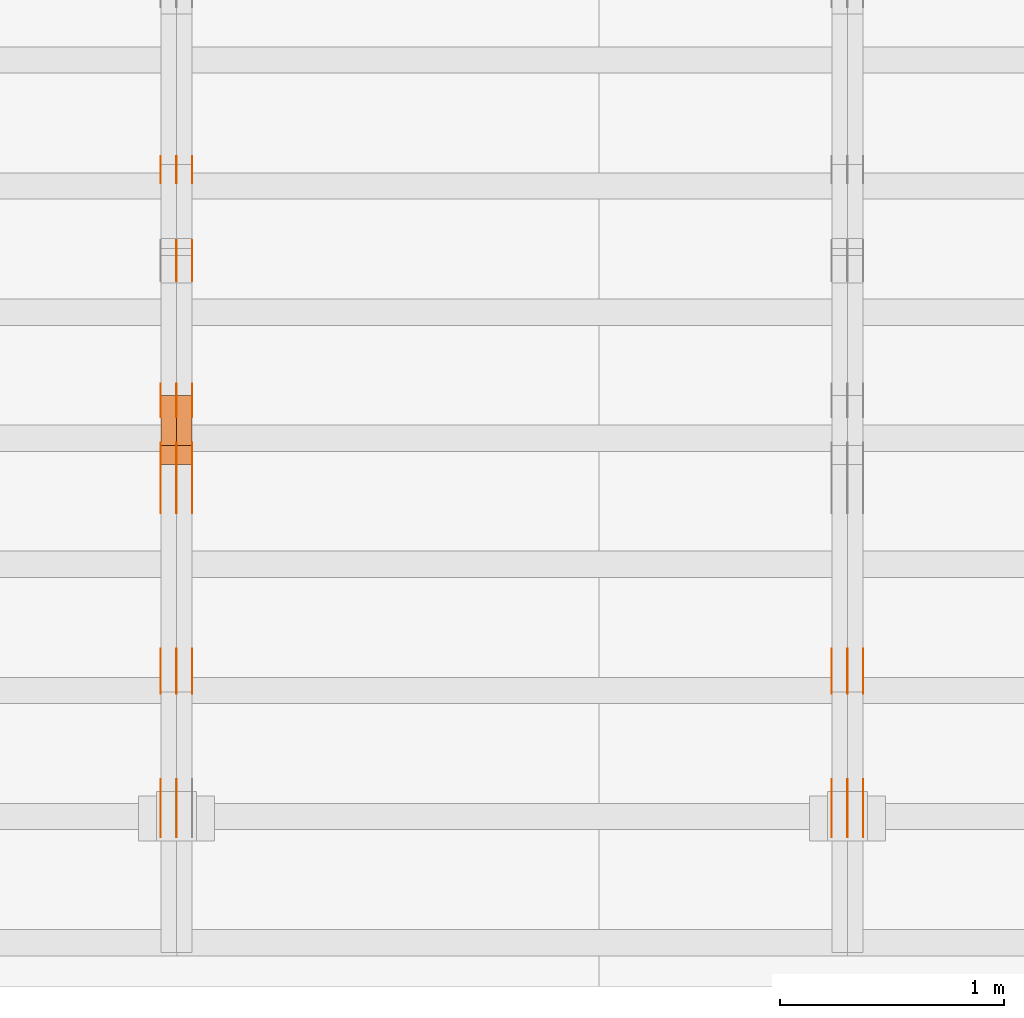
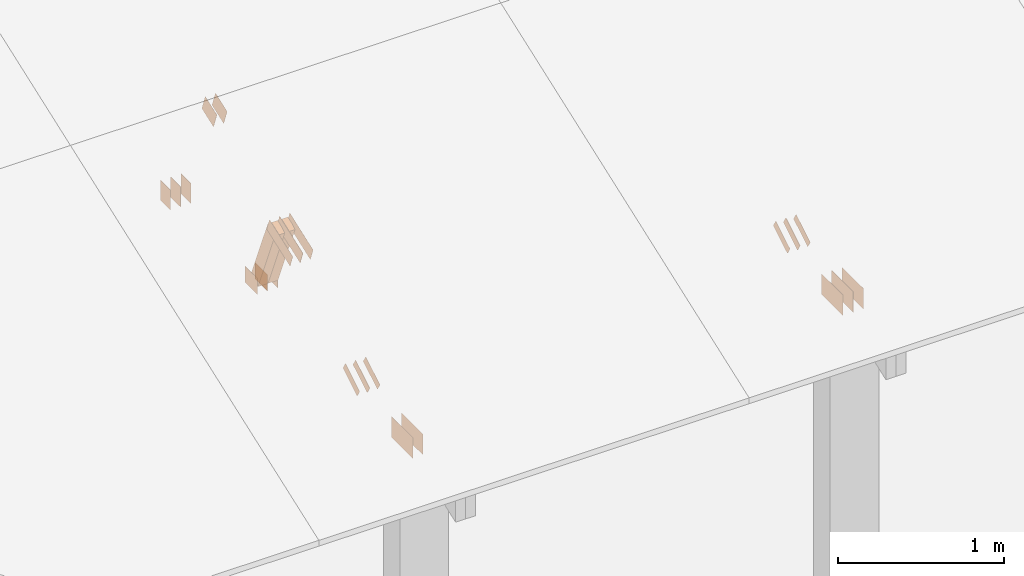
# One storey, part 68 of 189: 30 proxies.
"""IFC2X3 building model written with IfcOpenShell, lengths in millimetres."""

from ifc_helpers import new_model, entity, si_unit, converted_unit, derived_unit, direction, frame, frame_2d, origin, origin_2d_with_axis, place, context, subcontext, project, spatial, polyline, rectangle, outline, extrude, source, transform, mapped, material, type_object, type_shapes, element, save


model = new_model("IFC2X3")

# Units and contexts
model_context = context("Model", 3, precision=0.01, world=origin(), true_north=direction((6.12303176911189e-17, 1.0)))
body_context = subcontext(model_context, "Body", "Model", "MODEL_VIEW")
ifc_project = project(units=[si_unit("LENGTHUNIT", "METRE", prefix="MILLI"), si_unit("AREAUNIT", "SQUARE_METRE"), si_unit("VOLUMEUNIT", "CUBIC_METRE"), converted_unit("PLANEANGLEUNIT", "DEGREE", entity("IfcRatioMeasure", 0.0174532925199433), si_unit("PLANEANGLEUNIT", "RADIAN"), dimensions=[0, 0, 0, 0, 0, 0, 0]), si_unit("MASSUNIT", "GRAM", prefix="KILO"), derived_unit("MASSDENSITYUNIT", [(si_unit("MASSUNIT", "GRAM", prefix="KILO"), 1), (si_unit("LENGTHUNIT", "METRE"), -3)]), si_unit("TIMEUNIT", "SECOND"), si_unit("FREQUENCYUNIT", "HERTZ"), si_unit("THERMODYNAMICTEMPERATUREUNIT", "DEGREE_CELSIUS"), derived_unit("THERMALTRANSMITTANCEUNIT", [(si_unit("MASSUNIT", "GRAM", prefix="KILO"), 1), (si_unit("THERMODYNAMICTEMPERATUREUNIT", "KELVIN"), -1), (si_unit("TIMEUNIT", "SECOND"), -3)]), derived_unit("VOLUMETRICFLOWRATEUNIT", [(si_unit("LENGTHUNIT", "METRE"), 3), (si_unit("TIMEUNIT", "SECOND"), -1)]), si_unit("ELECTRICCURRENTUNIT", "AMPERE"), si_unit("ELECTRICVOLTAGEUNIT", "VOLT"), si_unit("POWERUNIT", "WATT"), si_unit("FORCEUNIT", "NEWTON"), si_unit("ILLUMINANCEUNIT", "LUX"), si_unit("LUMINOUSFLUXUNIT", "LUMEN"), si_unit("LUMINOUSINTENSITYUNIT", "CANDELA"), derived_unit("USERDEFINED", [(si_unit("MASSUNIT", "GRAM", prefix="KILO"), -1), (si_unit("LENGTHUNIT", "METRE"), -2), (si_unit("TIMEUNIT", "SECOND"), 3), (si_unit("LUMINOUSFLUXUNIT", "LUMEN"), 1)]), derived_unit("LINEARVELOCITYUNIT", [(si_unit("LENGTHUNIT", "METRE"), 1), (si_unit("TIMEUNIT", "SECOND"), -1)]), si_unit("PRESSUREUNIT", "PASCAL"), derived_unit("USERDEFINED", [(si_unit("LENGTHUNIT", "METRE"), -2), (si_unit("MASSUNIT", "GRAM", prefix="KILO"), 1), (si_unit("TIMEUNIT", "SECOND"), -2)])], contexts=[model_context])

# Site, building, storey
site_placement = place(None, origin())
site = spatial("IfcSite", under=ifc_project, at=site_placement, CompositionType="ELEMENT")
building_placement = place(site_placement, origin())
building = spatial("IfcBuilding", under=site, at=building_placement, CompositionType="ELEMENT")
storey_placement = place(building_placement, origin())
storey = spatial("IfcBuildingStorey", under=building, at=storey_placement, Name="Default", CompositionType="ELEMENT", Elevation=0.0)

# Proxies
ifc_material_1 = material(Name="IfcSurfaceStyle #40126")
building_element_proxy_type_1 = type_object("IfcBuildingElementProxyType", PredefinedType="NOTDEFINED", material=ifc_material_1)
shared_shape_1 = source(origin(), body_context, "Body", "SweptSolid", [
    extrude(outline(polyline([(-100.000388510424, -29.9995882393532), (100.000691805256, -29.9995882393532), (100.000392424258, 29.9995882393532), (-100.00069571909, 29.9995882393532), (-100.000388510424, -29.9995882393532)])), frame((100.000691805256, 30.0002299338894, 0.0), z_axis=(0.0, 0.0, 1.0), x_axis=(-1.0, 0.0, 0.0)), (0.0, 0.0, 1.0), 1.3),
])
type_shapes(building_element_proxy_type_1, [shared_shape_1])
proxy_1_placement = place(building_placement, frame((6336.3, 656.945055513712, 219.45219322107), z_axis=(-1.0, 0.0, 0.0), x_axis=(0.0, 0.858392121304013, 0.51299411895576)))
element("IfcBuildingElementProxy", 1, at=proxy_1_placement, inside=storey, type_object=building_element_proxy_type_1, material=ifc_material_1, context=body_context, shape_type="MappedRepresentation", body=[
    mapped(shared_shape_1, transform((0.0, 0.0, 0.0), scale=1.0)),
])
ifc_material_2 = material(Name="IfcSurfaceStyle #40069")
building_element_proxy_type_2 = type_object("IfcBuildingElementProxyType", PredefinedType="NOTDEFINED", material=ifc_material_2)
shared_shape_2 = source(origin(), body_context, "Body", "SweptSolid", [
    extrude(outline(polyline([(-100.000388510424, -29.9995882393532), (100.000691805256, -29.9995882393532), (100.000392424258, 29.9995882393532), (-100.00069571909, 29.9995882393532), (-100.000388510424, -29.9995882393532)])), frame((100.000691805256, 30.0002299338894, 0.0), z_axis=(0.0, 0.0, 1.0), x_axis=(-1.0, 0.0, 0.0)), (0.0, 0.0, 1.0), 1.29999999999998),
])
type_shapes(building_element_proxy_type_2, [shared_shape_2])
proxy_2_placement = place(building_placement, frame((6265.0, 656.945055513712, 219.45219322107), z_axis=(-1.0, 0.0, 0.0), x_axis=(0.0, 0.858392121304013, 0.51299411895576)))
element("IfcBuildingElementProxy", 2, at=proxy_2_placement, inside=storey, type_object=building_element_proxy_type_2, material=ifc_material_2, context=body_context, shape_type="MappedRepresentation", body=[
    mapped(shared_shape_2, transform((0.0, 0.0, 0.0), scale=1.0)),
])
ifc_material_3 = material(Name="IfcSurfaceStyle #40012")
building_element_proxy_type_3 = type_object("IfcBuildingElementProxyType", PredefinedType="NOTDEFINED", material=ifc_material_3)
shared_shape_3 = source(origin(), body_context, "Body", "SweptSolid", [
    extrude(outline(polyline([(-100.000388510424, -29.9995882393532), (100.000691805256, -29.9995882393532), (100.000392424258, 29.9995882393532), (-100.00069571909, 29.9995882393532), (-100.000388510424, -29.9995882393532)])), frame((100.000691805256, 30.0002299338894, 0.0), z_axis=(0.0, 0.0, 1.0), x_axis=(-1.0, 0.0, 0.0)), (0.0, 0.0, 1.0), 1.29999999999998),
])
type_shapes(building_element_proxy_type_3, [shared_shape_3])
proxy_3_placement = place(building_placement, frame((6266.3, 656.945055513712, 219.45219322107), z_axis=(-1.0, 0.0, 0.0), x_axis=(0.0, 0.858392121304013, 0.51299411895576)))
element("IfcBuildingElementProxy", 3, at=proxy_3_placement, inside=storey, type_object=building_element_proxy_type_3, material=ifc_material_3, context=body_context, shape_type="MappedRepresentation", body=[
    mapped(shared_shape_3, transform((0.0, 0.0, 0.0), scale=1.0)),
])
ifc_material_4 = material(Name="IfcSurfaceStyle #39955")
building_element_proxy_type_4 = type_object("IfcBuildingElementProxyType", PredefinedType="NOTDEFINED", material=ifc_material_4)
shared_shape_4 = source(origin(), body_context, "Body", "SweptSolid", [
    extrude(outline(polyline([(-100.000388510424, -29.9995882393532), (100.000691805256, -29.9995882393532), (100.000392424258, 29.9995882393532), (-100.00069571909, 29.9995882393532), (-100.000388510424, -29.9995882393532)])), frame((100.000691805256, 30.0002299338894, 0.0), z_axis=(0.0, 0.0, 1.0), x_axis=(-1.0, 0.0, 0.0)), (0.0, 0.0, 1.0), 1.29999999999999),
])
type_shapes(building_element_proxy_type_4, [shared_shape_4])
proxy_4_placement = place(building_placement, frame((6195.0, 656.945055513712, 219.45219322107), z_axis=(-1.0, 0.0, 0.0), x_axis=(0.0, 0.858392121304013, 0.51299411895576)))
element("IfcBuildingElementProxy", 4, at=proxy_4_placement, inside=storey, type_object=building_element_proxy_type_4, material=ifc_material_4, context=body_context, shape_type="MappedRepresentation", body=[
    mapped(shared_shape_4, transform((0.0, 0.0, 0.0), scale=1.0)),
])
ifc_material_5 = material(Name="IfcSurfaceStyle #38590")
building_element_proxy_type_5 = type_object("IfcBuildingElementProxyType", PredefinedType="NOTDEFINED", material=ifc_material_5)
shared_shape_5 = source(origin(), body_context, "Body", "SweptSolid", [
    extrude(rectangle(XDim=258.0, YDim=151.999992370605, at=origin_2d_with_axis()), frame((129.0, 76.0000049445079, 0.0), z_axis=(0.0, 0.0, 1.0), x_axis=(-1.0, 0.0, 0.0)), (0.0, 0.0, 1.0), 0.999999999999984),
])
type_shapes(building_element_proxy_type_5, [shared_shape_5])
proxy_5_placement = place(building_placement, frame((6336.0, 16.236328125, 268.138222870533), z_axis=(-1.0, 0.0, 0.0), x_axis=(0.0, 1.0, 0.0)))
element("IfcBuildingElementProxy", 5, at=proxy_5_placement, inside=storey, type_object=building_element_proxy_type_5, material=ifc_material_5, Name="GNT100S 152x258", context=body_context, shape_type="MappedRepresentation", body=[
    mapped(shared_shape_5, transform((0.0, 0.0, 0.0), scale=1.0)),
])
ifc_material_6 = material(Name="IfcSurfaceStyle #38533")
building_element_proxy_type_6 = type_object("IfcBuildingElementProxyType", PredefinedType="NOTDEFINED", material=ifc_material_6)
shared_shape_6 = source(origin(), body_context, "Body", "SweptSolid", [
    extrude(rectangle(XDim=258.0, YDim=151.999992370605, at=origin_2d_with_axis()), frame((129.0, 76.0000049445079, 0.0), z_axis=(0.0, 0.0, 1.0), x_axis=(-1.0, 0.0, 0.0)), (0.0, 0.0, 1.0), 0.999999999999984),
])
type_shapes(building_element_proxy_type_6, [shared_shape_6])
proxy_6_placement = place(building_placement, frame((6265.0, 16.236328125, 268.138222870533), z_axis=(-1.0, 0.0, 0.0), x_axis=(0.0, 1.0, 0.0)))
element("IfcBuildingElementProxy", 6, at=proxy_6_placement, inside=storey, type_object=building_element_proxy_type_6, material=ifc_material_6, Name="GNT100S 152x258", context=body_context, shape_type="MappedRepresentation", body=[
    mapped(shared_shape_6, transform((0.0, 0.0, 0.0), scale=1.0)),
])
ifc_material_7 = material(Name="IfcSurfaceStyle #38476")
building_element_proxy_type_7 = type_object("IfcBuildingElementProxyType", PredefinedType="NOTDEFINED", material=ifc_material_7)
shared_shape_7 = source(origin(), body_context, "Body", "SweptSolid", [
    extrude(rectangle(XDim=258.0, YDim=151.999992370605, at=origin_2d_with_axis()), frame((129.0, 76.0000049445079, 0.0), z_axis=(0.0, 0.0, 1.0), x_axis=(-1.0, 0.0, 0.0)), (0.0, 0.0, 1.0), 0.999999999999984),
])
type_shapes(building_element_proxy_type_7, [shared_shape_7])
proxy_7_placement = place(building_placement, frame((6266.0, 16.236328125, 268.138222870533), z_axis=(-1.0, 0.0, 0.0), x_axis=(0.0, 1.0, 0.0)))
element("IfcBuildingElementProxy", 7, at=proxy_7_placement, inside=storey, type_object=building_element_proxy_type_7, material=ifc_material_7, Name="GNT100S 152x258", context=body_context, shape_type="MappedRepresentation", body=[
    mapped(shared_shape_7, transform((0.0, 0.0, 0.0), scale=1.0)),
])
ifc_material_8 = material(Name="IfcSurfaceStyle #38419")
building_element_proxy_type_8 = type_object("IfcBuildingElementProxyType", PredefinedType="NOTDEFINED", material=ifc_material_8)
shared_shape_8 = source(origin(), body_context, "Body", "SweptSolid", [
    extrude(rectangle(XDim=258.0, YDim=151.999992370605, at=origin_2d_with_axis()), frame((129.0, 76.0000049445079, 0.0), z_axis=(0.0, 0.0, 1.0), x_axis=(-1.0, 0.0, 0.0)), (0.0, 0.0, 1.0), 0.999999999999984),
])
type_shapes(building_element_proxy_type_8, [shared_shape_8])
proxy_8_placement = place(building_placement, frame((6195.0, 16.236328125, 268.138222870533), z_axis=(-1.0, 0.0, 0.0), x_axis=(0.0, 1.0, 0.0)))
element("IfcBuildingElementProxy", 8, at=proxy_8_placement, inside=storey, type_object=building_element_proxy_type_8, material=ifc_material_8, Name="GNT100S 152x258", context=body_context, shape_type="MappedRepresentation", body=[
    mapped(shared_shape_8, transform((0.0, 0.0, 0.0), scale=1.0)),
])
ifc_material_9 = material(Name="IfcSurfaceStyle #26160")
building_element_proxy_type_9 = type_object("IfcBuildingElementProxyType", PredefinedType="NOTDEFINED", material=ifc_material_9)
shared_shape_9 = source(origin(), body_context, "Body", "SweptSolid", [
    extrude(rectangle(XDim=150.0, YDim=120.0, at=frame_2d((1.4210854715202e-14, -7.105427357601e-15), x_axis=(1.0, 0.0))), frame((75.0, 60.0004961323721, 0.0), z_axis=(0.0, 0.0, 1.0), x_axis=(-1.0, 0.0, 0.0)), (0.0, 0.0, 1.0), 1.3),
])
type_shapes(building_element_proxy_type_9, [shared_shape_9])
proxy_9_placement = place(building_placement, frame((3336.3, 2940.99169136763, 170.0), z_axis=(-1.0, 0.0, 0.0), x_axis=(0.0, 0.0, 1.0)))
element("IfcBuildingElementProxy", 9, at=proxy_9_placement, inside=storey, type_object=building_element_proxy_type_9, material=ifc_material_9, context=body_context, shape_type="MappedRepresentation", body=[
    mapped(shared_shape_9, transform((0.0, 0.0, 0.0), scale=1.0)),
])
ifc_material_10 = material(Name="IfcSurfaceStyle #26103")
building_element_proxy_type_10 = type_object("IfcBuildingElementProxyType", PredefinedType="NOTDEFINED", material=ifc_material_10)
shared_shape_10 = source(origin(), body_context, "Body", "SweptSolid", [
    extrude(rectangle(XDim=150.0, YDim=120.0, at=frame_2d((1.4210854715202e-14, -7.105427357601e-15), x_axis=(1.0, 0.0))), frame((75.0, 60.0004961323721, 0.0), z_axis=(0.0, 0.0, 1.0), x_axis=(-1.0, 0.0, 0.0)), (0.0, 0.0, 1.0), 1.29999999999999),
])
type_shapes(building_element_proxy_type_10, [shared_shape_10])
proxy_10_placement = place(building_placement, frame((3265.0, 2940.99169136763, 170.0), z_axis=(-1.0, 0.0, 0.0), x_axis=(0.0, 0.0, 1.0)))
element("IfcBuildingElementProxy", 10, at=proxy_10_placement, inside=storey, type_object=building_element_proxy_type_10, material=ifc_material_10, context=body_context, shape_type="MappedRepresentation", body=[
    mapped(shared_shape_10, transform((0.0, 0.0, 0.0), scale=1.0)),
])
ifc_material_11 = material(Name="IfcSurfaceStyle #26046")
building_element_proxy_type_11 = type_object("IfcBuildingElementProxyType", PredefinedType="NOTDEFINED", material=ifc_material_11)
shared_shape_11 = source(origin(), body_context, "Body", "SweptSolid", [
    extrude(rectangle(XDim=150.0, YDim=120.0, at=frame_2d((1.4210854715202e-14, -7.105427357601e-15), x_axis=(1.0, 0.0))), frame((75.0, 60.0004961323721, 0.0), z_axis=(0.0, 0.0, 1.0), x_axis=(-1.0, 0.0, 0.0)), (0.0, 0.0, 1.0), 1.29999999999999),
])
type_shapes(building_element_proxy_type_11, [shared_shape_11])
proxy_11_placement = place(building_placement, frame((3266.3, 2940.99169136763, 170.0), z_axis=(-1.0, 0.0, 0.0), x_axis=(0.0, 0.0, 1.0)))
element("IfcBuildingElementProxy", 11, at=proxy_11_placement, inside=storey, type_object=building_element_proxy_type_11, material=ifc_material_11, context=body_context, shape_type="MappedRepresentation", body=[
    mapped(shared_shape_11, transform((0.0, 0.0, 0.0), scale=1.0)),
])
ifc_material_12 = material(Name="IfcSurfaceStyle #25989")
building_element_proxy_type_12 = type_object("IfcBuildingElementProxyType", PredefinedType="NOTDEFINED", material=ifc_material_12)
shared_shape_12 = source(origin(), body_context, "Body", "SweptSolid", [
    extrude(rectangle(XDim=150.0, YDim=120.0, at=frame_2d((1.4210854715202e-14, -7.105427357601e-15), x_axis=(1.0, 0.0))), frame((75.0, 60.0004961323721, 0.0), z_axis=(0.0, 0.0, 1.0), x_axis=(-1.0, 0.0, 0.0)), (0.0, 0.0, 1.0), 1.29999999999999),
])
type_shapes(building_element_proxy_type_12, [shared_shape_12])
proxy_12_placement = place(building_placement, frame((3195.0, 2940.99169136763, 170.0), z_axis=(-1.0, 0.0, 0.0), x_axis=(0.0, 0.0, 1.0)))
element("IfcBuildingElementProxy", 12, at=proxy_12_placement, inside=storey, type_object=building_element_proxy_type_12, material=ifc_material_12, context=body_context, shape_type="MappedRepresentation", body=[
    mapped(shared_shape_12, transform((0.0, 0.0, 0.0), scale=1.0)),
])
ifc_material_13 = material(Name="IfcSurfaceStyle #25932")
building_element_proxy_type_13 = type_object("IfcBuildingElementProxyType", PredefinedType="NOTDEFINED", material=ifc_material_13)
shared_shape_13 = source(origin(), body_context, "Body", "SweptSolid", [
    extrude(outline(polyline([(-75.0008071857483, -59.9999039432187), (75.0002916555677, -59.9999039432187), (75.0008280609982, 59.9999039432187), (-75.0003125308176, 59.9999039432187), (-75.0008071857483, -59.9999039432187)])), frame((75.0008280609982, 60.0002349219685, 0.0), z_axis=(0.0, 0.0, 1.0), x_axis=(-1.0, 0.0, 0.0)), (0.0, 0.0, 1.0), 1.3),
])
type_shapes(building_element_proxy_type_13, [shared_shape_13])
proxy_13_placement = place(building_placement, frame((3336.3, 2502.466796875, 1113.95080566406), z_axis=(-1.0, 0.0, 0.0), x_axis=(0.0, 0.939692620785908, 0.342020143325669)))
element("IfcBuildingElementProxy", 13, at=proxy_13_placement, inside=storey, type_object=building_element_proxy_type_13, material=ifc_material_13, context=body_context, shape_type="MappedRepresentation", body=[
    mapped(shared_shape_13, transform((0.0, 0.0, 0.0), scale=1.0)),
])
ifc_material_14 = material(Name="IfcSurfaceStyle #25875")
building_element_proxy_type_14 = type_object("IfcBuildingElementProxyType", PredefinedType="NOTDEFINED", material=ifc_material_14)
shared_shape_14 = source(origin(), body_context, "Body", "SweptSolid", [
    extrude(outline(polyline([(-75.0008071857483, -59.9999039432187), (75.0002916555677, -59.9999039432187), (75.0008280609982, 59.9999039432187), (-75.0003125308176, 59.9999039432187), (-75.0008071857483, -59.9999039432187)])), frame((75.0008280609982, 60.0002349219685, 0.0), z_axis=(0.0, 0.0, 1.0), x_axis=(-1.0, 0.0, 0.0)), (0.0, 0.0, 1.0), 1.29999999999999),
])
type_shapes(building_element_proxy_type_14, [shared_shape_14])
proxy_14_placement = place(building_placement, frame((3265.0, 2502.466796875, 1113.95080566406), z_axis=(-1.0, 0.0, 0.0), x_axis=(0.0, 0.939692620785908, 0.342020143325669)))
element("IfcBuildingElementProxy", 14, at=proxy_14_placement, inside=storey, type_object=building_element_proxy_type_14, material=ifc_material_14, context=body_context, shape_type="MappedRepresentation", body=[
    mapped(shared_shape_14, transform((0.0, 0.0, 0.0), scale=1.0)),
])
ifc_material_15 = material(Name="IfcSurfaceStyle #25248")
building_element_proxy_type_15 = type_object("IfcBuildingElementProxyType", PredefinedType="NOTDEFINED", material=ifc_material_15)
shared_shape_15 = source(origin(), body_context, "Body", "SweptSolid", [
    extrude(rectangle(XDim=150.0, YDim=120.0, at=origin_2d_with_axis()), frame((75.0004757715869, 60.0, 0.0), z_axis=(0.0, 0.0, 1.0), x_axis=(-1.0, 0.0, 0.0)), (0.0, 0.0, 1.0), 1.3),
])
type_shapes(building_element_proxy_type_15, [shared_shape_15])
proxy_15_placement = place(building_placement, frame((3336.3, 1892.68702422841, 305.0), z_axis=(-1.0, 0.0, 0.0), x_axis=(0.0, 1.0, 0.0)))
element("IfcBuildingElementProxy", 15, at=proxy_15_placement, inside=storey, type_object=building_element_proxy_type_15, material=ifc_material_15, context=body_context, shape_type="MappedRepresentation", body=[
    mapped(shared_shape_15, transform((0.0, 0.0, 0.0), scale=1.0)),
])
ifc_material_16 = material(Name="IfcSurfaceStyle #25191")
building_element_proxy_type_16 = type_object("IfcBuildingElementProxyType", PredefinedType="NOTDEFINED", material=ifc_material_16)
shared_shape_16 = source(origin(), body_context, "Body", "SweptSolid", [
    extrude(rectangle(XDim=150.0, YDim=120.0, at=origin_2d_with_axis()), frame((75.0004757715869, 60.0, 0.0), z_axis=(0.0, 0.0, 1.0), x_axis=(-1.0, 0.0, 0.0)), (0.0, 0.0, 1.0), 1.29999999999999),
])
type_shapes(building_element_proxy_type_16, [shared_shape_16])
proxy_16_placement = place(building_placement, frame((3265.0, 1892.68702422841, 305.0), z_axis=(-1.0, 0.0, 0.0), x_axis=(0.0, 1.0, 0.0)))
element("IfcBuildingElementProxy", 16, at=proxy_16_placement, inside=storey, type_object=building_element_proxy_type_16, material=ifc_material_16, context=body_context, shape_type="MappedRepresentation", body=[
    mapped(shared_shape_16, transform((0.0, 0.0, 0.0), scale=1.0)),
])
ifc_material_17 = material(Name="IfcSurfaceStyle #25134")
building_element_proxy_type_17 = type_object("IfcBuildingElementProxyType", PredefinedType="NOTDEFINED", material=ifc_material_17)
shared_shape_17 = source(origin(), body_context, "Body", "SweptSolid", [
    extrude(rectangle(XDim=150.0, YDim=120.0, at=origin_2d_with_axis()), frame((75.0004757715869, 60.0, 0.0), z_axis=(0.0, 0.0, 1.0), x_axis=(-1.0, 0.0, 0.0)), (0.0, 0.0, 1.0), 1.29999999999999),
])
type_shapes(building_element_proxy_type_17, [shared_shape_17])
proxy_17_placement = place(building_placement, frame((3266.3, 1892.68702422841, 305.0), z_axis=(-1.0, 0.0, 0.0), x_axis=(0.0, 1.0, 0.0)))
element("IfcBuildingElementProxy", 17, at=proxy_17_placement, inside=storey, type_object=building_element_proxy_type_17, material=ifc_material_17, context=body_context, shape_type="MappedRepresentation", body=[
    mapped(shared_shape_17, transform((0.0, 0.0, 0.0), scale=1.0)),
])
ifc_material_18 = material(Name="IfcSurfaceStyle #25077")
building_element_proxy_type_18 = type_object("IfcBuildingElementProxyType", PredefinedType="NOTDEFINED", material=ifc_material_18)
shared_shape_18 = source(origin(), body_context, "Body", "SweptSolid", [
    extrude(rectangle(XDim=150.0, YDim=120.0, at=origin_2d_with_axis()), frame((75.0004757715869, 60.0, 0.0), z_axis=(0.0, 0.0, 1.0), x_axis=(-1.0, 0.0, 0.0)), (0.0, 0.0, 1.0), 1.29999999999999),
])
type_shapes(building_element_proxy_type_18, [shared_shape_18])
proxy_18_placement = place(building_placement, frame((3195.0, 1892.68702422841, 305.0), z_axis=(-1.0, 0.0, 0.0), x_axis=(0.0, 1.0, 0.0)))
element("IfcBuildingElementProxy", 18, at=proxy_18_placement, inside=storey, type_object=building_element_proxy_type_18, material=ifc_material_18, context=body_context, shape_type="MappedRepresentation", body=[
    mapped(shared_shape_18, transform((0.0, 0.0, 0.0), scale=1.0)),
])
ifc_material_19 = material(Name="IfcSurfaceStyle #25020")
building_element_proxy_type_19 = type_object("IfcBuildingElementProxyType", PredefinedType="NOTDEFINED", material=ifc_material_19)
shared_shape_19 = source(origin(), body_context, "Body", "SweptSolid", [
    extrude(outline(polyline([(-150.000217420008, -47.9999344162752), (150.000165800718, -47.9999344162752), (150.000227857633, 47.9999344162752), (-150.000176238343, 47.9999344162752), (-150.000217420008, -47.9999344162752)])), frame((150.000227857633, 48.0000430742566, 0.0), z_axis=(0.0, 0.0, 1.0), x_axis=(-1.0, 0.0, 0.0)), (0.0, 0.0, 1.0), 1.29999999999999),
])
type_shapes(building_element_proxy_type_19, [shared_shape_19])
proxy_19_placement = place(building_placement, frame((3336.3, 1464.46484375, 723.378723144533), z_axis=(-1.0, 0.0, 0.0), x_axis=(0.0, 0.939692620785908, 0.342020143325669)))
element("IfcBuildingElementProxy", 19, at=proxy_19_placement, inside=storey, type_object=building_element_proxy_type_19, material=ifc_material_19, context=body_context, shape_type="MappedRepresentation", body=[
    mapped(shared_shape_19, transform((0.0, 0.0, 0.0), scale=1.0)),
])
ifc_material_20 = material(Name="IfcSurfaceStyle #24963")
building_element_proxy_type_20 = type_object("IfcBuildingElementProxyType", PredefinedType="NOTDEFINED", material=ifc_material_20)
shared_shape_20 = source(origin(), body_context, "Body", "SweptSolid", [
    extrude(outline(polyline([(-150.000217420008, -47.9999344162752), (150.000165800718, -47.9999344162752), (150.000227857633, 47.9999344162752), (-150.000176238343, 47.9999344162752), (-150.000217420008, -47.9999344162752)])), frame((150.000227857633, 48.0000430742566, 0.0), z_axis=(0.0, 0.0, 1.0), x_axis=(-1.0, 0.0, 0.0)), (0.0, 0.0, 1.0), 1.29999999999998),
])
type_shapes(building_element_proxy_type_20, [shared_shape_20])
proxy_20_placement = place(building_placement, frame((3265.0, 1464.46484375, 723.378723144533), z_axis=(-1.0, 0.0, 0.0), x_axis=(0.0, 0.939692620785908, 0.342020143325669)))
element("IfcBuildingElementProxy", 20, at=proxy_20_placement, inside=storey, type_object=building_element_proxy_type_20, material=ifc_material_20, context=body_context, shape_type="MappedRepresentation", body=[
    mapped(shared_shape_20, transform((0.0, 0.0, 0.0), scale=1.0)),
])
ifc_material_21 = material(Name="IfcSurfaceStyle #24906")
building_element_proxy_type_21 = type_object("IfcBuildingElementProxyType", PredefinedType="NOTDEFINED", material=ifc_material_21)
shared_shape_21 = source(origin(), body_context, "Body", "SweptSolid", [
    extrude(outline(polyline([(-150.000217420008, -47.9999344162752), (150.000165800718, -47.9999344162752), (150.000227857633, 47.9999344162752), (-150.000176238343, 47.9999344162752), (-150.000217420008, -47.9999344162752)])), frame((150.000227857633, 48.0000430742566, 0.0), z_axis=(0.0, 0.0, 1.0), x_axis=(-1.0, 0.0, 0.0)), (0.0, 0.0, 1.0), 1.29999999999998),
])
type_shapes(building_element_proxy_type_21, [shared_shape_21])
proxy_21_placement = place(building_placement, frame((3266.3, 1464.46484375, 723.378723144533), z_axis=(-1.0, 0.0, 0.0), x_axis=(0.0, 0.939692620785908, 0.342020143325669)))
element("IfcBuildingElementProxy", 21, at=proxy_21_placement, inside=storey, type_object=building_element_proxy_type_21, material=ifc_material_21, context=body_context, shape_type="MappedRepresentation", body=[
    mapped(shared_shape_21, transform((0.0, 0.0, 0.0), scale=1.0)),
])
ifc_material_22 = material(Name="IfcSurfaceStyle #24849")
building_element_proxy_type_22 = type_object("IfcBuildingElementProxyType", PredefinedType="NOTDEFINED", material=ifc_material_22)
shared_shape_22 = source(origin(), body_context, "Body", "SweptSolid", [
    extrude(outline(polyline([(-150.000217420008, -47.9999344162752), (150.000165800718, -47.9999344162752), (150.000227857633, 47.9999344162752), (-150.000176238343, 47.9999344162752), (-150.000217420008, -47.9999344162752)])), frame((150.000227857633, 48.0000430742566, 0.0), z_axis=(0.0, 0.0, 1.0), x_axis=(-1.0, 0.0, 0.0)), (0.0, 0.0, 1.0), 1.29999999999998),
])
type_shapes(building_element_proxy_type_22, [shared_shape_22])
proxy_22_placement = place(building_placement, frame((3195.0, 1464.46484375, 723.378723144533), z_axis=(-1.0, 0.0, 0.0), x_axis=(0.0, 0.939692620785908, 0.342020143325669)))
element("IfcBuildingElementProxy", 22, at=proxy_22_placement, inside=storey, type_object=building_element_proxy_type_22, material=ifc_material_22, context=body_context, shape_type="MappedRepresentation", body=[
    mapped(shared_shape_22, transform((0.0, 0.0, 0.0), scale=1.0)),
])
ifc_material_23 = material(Name="IfcSurfaceStyle #24336")
building_element_proxy_type_23 = type_object("IfcBuildingElementProxyType", PredefinedType="NOTDEFINED", material=ifc_material_23)
shared_shape_23 = source(origin(), body_context, "Body", "SweptSolid", [
    extrude(outline(polyline([(-100.000388510424, -29.9995882393532), (100.000691805256, -29.9995882393532), (100.000392424258, 29.9995882393532), (-100.00069571909, 29.9995882393532), (-100.000388510424, -29.9995882393532)])), frame((100.000691805256, 30.0002299338894, 0.0), z_axis=(0.0, 0.0, 1.0), x_axis=(-1.0, 0.0, 0.0)), (0.0, 0.0, 1.0), 1.3),
])
type_shapes(building_element_proxy_type_23, [shared_shape_23])
proxy_23_placement = place(building_placement, frame((3336.3, 656.945055513712, 219.45219322107), z_axis=(-1.0, 0.0, 0.0), x_axis=(0.0, 0.858392121304013, 0.51299411895576)))
element("IfcBuildingElementProxy", 23, at=proxy_23_placement, inside=storey, type_object=building_element_proxy_type_23, material=ifc_material_23, context=body_context, shape_type="MappedRepresentation", body=[
    mapped(shared_shape_23, transform((0.0, 0.0, 0.0), scale=1.0)),
])
ifc_material_24 = material(Name="IfcSurfaceStyle #24279")
building_element_proxy_type_24 = type_object("IfcBuildingElementProxyType", PredefinedType="NOTDEFINED", material=ifc_material_24)
shared_shape_24 = source(origin(), body_context, "Body", "SweptSolid", [
    extrude(outline(polyline([(-100.000388510424, -29.9995882393532), (100.000691805256, -29.9995882393532), (100.000392424258, 29.9995882393532), (-100.00069571909, 29.9995882393532), (-100.000388510424, -29.9995882393532)])), frame((100.000691805256, 30.0002299338894, 0.0), z_axis=(0.0, 0.0, 1.0), x_axis=(-1.0, 0.0, 0.0)), (0.0, 0.0, 1.0), 1.29999999999998),
])
type_shapes(building_element_proxy_type_24, [shared_shape_24])
proxy_24_placement = place(building_placement, frame((3265.0, 656.945055513712, 219.45219322107), z_axis=(-1.0, 0.0, 0.0), x_axis=(0.0, 0.858392121304013, 0.51299411895576)))
element("IfcBuildingElementProxy", 24, at=proxy_24_placement, inside=storey, type_object=building_element_proxy_type_24, material=ifc_material_24, context=body_context, shape_type="MappedRepresentation", body=[
    mapped(shared_shape_24, transform((0.0, 0.0, 0.0), scale=1.0)),
])
ifc_material_25 = material(Name="IfcSurfaceStyle #24222")
building_element_proxy_type_25 = type_object("IfcBuildingElementProxyType", PredefinedType="NOTDEFINED", material=ifc_material_25)
shared_shape_25 = source(origin(), body_context, "Body", "SweptSolid", [
    extrude(outline(polyline([(-100.000388510424, -29.9995882393532), (100.000691805256, -29.9995882393532), (100.000392424258, 29.9995882393532), (-100.00069571909, 29.9995882393532), (-100.000388510424, -29.9995882393532)])), frame((100.000691805256, 30.0002299338894, 0.0), z_axis=(0.0, 0.0, 1.0), x_axis=(-1.0, 0.0, 0.0)), (0.0, 0.0, 1.0), 1.29999999999998),
])
type_shapes(building_element_proxy_type_25, [shared_shape_25])
proxy_25_placement = place(building_placement, frame((3266.3, 656.945055513712, 219.45219322107), z_axis=(-1.0, 0.0, 0.0), x_axis=(0.0, 0.858392121304013, 0.51299411895576)))
element("IfcBuildingElementProxy", 25, at=proxy_25_placement, inside=storey, type_object=building_element_proxy_type_25, material=ifc_material_25, context=body_context, shape_type="MappedRepresentation", body=[
    mapped(shared_shape_25, transform((0.0, 0.0, 0.0), scale=1.0)),
])
ifc_material_26 = material(Name="IfcSurfaceStyle #24165")
building_element_proxy_type_26 = type_object("IfcBuildingElementProxyType", PredefinedType="NOTDEFINED", material=ifc_material_26)
shared_shape_26 = source(origin(), body_context, "Body", "SweptSolid", [
    extrude(outline(polyline([(-100.000388510424, -29.9995882393532), (100.000691805256, -29.9995882393532), (100.000392424258, 29.9995882393532), (-100.00069571909, 29.9995882393532), (-100.000388510424, -29.9995882393532)])), frame((100.000691805256, 30.0002299338894, 0.0), z_axis=(0.0, 0.0, 1.0), x_axis=(-1.0, 0.0, 0.0)), (0.0, 0.0, 1.0), 1.29999999999999),
])
type_shapes(building_element_proxy_type_26, [shared_shape_26])
proxy_26_placement = place(building_placement, frame((3195.0, 656.945055513712, 219.45219322107), z_axis=(-1.0, 0.0, 0.0), x_axis=(0.0, 0.858392121304013, 0.51299411895576)))
element("IfcBuildingElementProxy", 26, at=proxy_26_placement, inside=storey, type_object=building_element_proxy_type_26, material=ifc_material_26, context=body_context, shape_type="MappedRepresentation", body=[
    mapped(shared_shape_26, transform((0.0, 0.0, 0.0), scale=1.0)),
])
ifc_material_27 = material(Name="IfcSurfaceStyle #22686")
building_element_proxy_type_27 = type_object("IfcBuildingElementProxyType", PredefinedType="NOTDEFINED", material=ifc_material_27)
shared_shape_27 = source(origin(), body_context, "Body", "SweptSolid", [
    extrude(rectangle(XDim=258.0, YDim=151.999992370605, at=origin_2d_with_axis()), frame((129.0, 76.0000049445079, 0.0), z_axis=(0.0, 0.0, 1.0), x_axis=(-1.0, 0.0, 0.0)), (0.0, 0.0, 1.0), 0.999999999999984),
])
type_shapes(building_element_proxy_type_27, [shared_shape_27])
proxy_27_placement = place(building_placement, frame((3266.0, 16.236328125, 268.138222870533), z_axis=(-1.0, 0.0, 0.0), x_axis=(0.0, 1.0, 0.0)))
element("IfcBuildingElementProxy", 27, at=proxy_27_placement, inside=storey, type_object=building_element_proxy_type_27, material=ifc_material_27, Name="GNT100S 152x258", context=body_context, shape_type="MappedRepresentation", body=[
    mapped(shared_shape_27, transform((0.0, 0.0, 0.0), scale=1.0)),
])
ifc_material_28 = material(Name="IfcSurfaceStyle #22629")
building_element_proxy_type_28 = type_object("IfcBuildingElementProxyType", PredefinedType="NOTDEFINED", material=ifc_material_28)
shared_shape_28 = source(origin(), body_context, "Body", "SweptSolid", [
    extrude(rectangle(XDim=258.0, YDim=151.999992370605, at=origin_2d_with_axis()), frame((129.0, 76.0000049445079, 0.0), z_axis=(0.0, 0.0, 1.0), x_axis=(-1.0, 0.0, 0.0)), (0.0, 0.0, 1.0), 0.999999999999984),
])
type_shapes(building_element_proxy_type_28, [shared_shape_28])
proxy_28_placement = place(building_placement, frame((3195.0, 16.236328125, 268.138222870533), z_axis=(-1.0, 0.0, 0.0), x_axis=(0.0, 1.0, 0.0)))
element("IfcBuildingElementProxy", 28, at=proxy_28_placement, inside=storey, type_object=building_element_proxy_type_28, material=ifc_material_28, Name="GNT100S 152x258", context=body_context, shape_type="MappedRepresentation", body=[
    mapped(shared_shape_28, transform((0.0, 0.0, 0.0), scale=1.0)),
])
ifc_material_29 = material(Name="IfcSurfaceStyle #17832")
building_element_proxy_type_29 = type_object("IfcBuildingElementProxyType", Name="T1-W15 17830", PredefinedType="NOTDEFINED", material=ifc_material_29)
shared_shape_29 = source(origin(), body_context, "Body", "SweptSolid", [
    extrude(outline(polyline([(-317.132720418368, -47.5005147440206), (220.445242566881, -47.5005147440206), (227.5021778825, -0.000126286009697951), (225.500088907744, 47.5005778870255), (-356.314788938758, 47.5005778870255), (-317.132720418368, -47.5005147440206)])), frame((227.5021778825, 47.5005778870255, 0.0), z_axis=(0.0, 0.0, 1.0), x_axis=(-1.0, 0.0, 0.0)), (0.0, 0.0, 1.0), 70.0),
])
type_shapes(building_element_proxy_type_29, [shared_shape_29])
proxy_29_placement = place(building_placement, frame((3335.0, 1767.47882447529, 784.714556181707), z_axis=(-1.0, 0.0, 0.0), x_axis=(0.0, 0.381283266795389, -0.924458257825542)))
element("IfcBuildingElementProxy", 29, at=proxy_29_placement, inside=storey, type_object=building_element_proxy_type_29, material=ifc_material_29, Name="T1-W15", context=body_context, shape_type="MappedRepresentation", body=[
    mapped(shared_shape_29, transform((0.0, 0.0, 0.0), scale=1.0)),
])
ifc_material_30 = material(Name="IfcSurfaceStyle #17766")
building_element_proxy_type_30 = type_object("IfcBuildingElementProxyType", Name="T1-W15 17764", PredefinedType="NOTDEFINED", material=ifc_material_30)
shared_shape_30 = source(origin(), body_context, "Body", "SweptSolid", [
    extrude(outline(polyline([(-317.132720418368, -47.5005147440206), (220.445242566881, -47.5005147440206), (227.5021778825, -0.000126286009697951), (225.500088907744, 47.5005778870255), (-356.314788938758, 47.5005778870255), (-317.132720418368, -47.5005147440206)])), frame((227.5021778825, 47.5005778870255, 0.0), z_axis=(0.0, 0.0, 1.0), x_axis=(-1.0, 0.0, 0.0)), (0.0, 0.0, 1.0), 70.0),
])
type_shapes(building_element_proxy_type_30, [shared_shape_30])
proxy_30_placement = place(building_placement, frame((3265.0, 1767.47882447529, 784.714556181707), z_axis=(-1.0, 0.0, 0.0), x_axis=(0.0, 0.381283266795389, -0.924458257825542)))
element("IfcBuildingElementProxy", 30, at=proxy_30_placement, inside=storey, type_object=building_element_proxy_type_30, material=ifc_material_30, Name="T1-W15", context=body_context, shape_type="MappedRepresentation", body=[
    mapped(shared_shape_30, transform((0.0, 0.0, 0.0), scale=1.0)),
])

save(model, "model.ifc")
